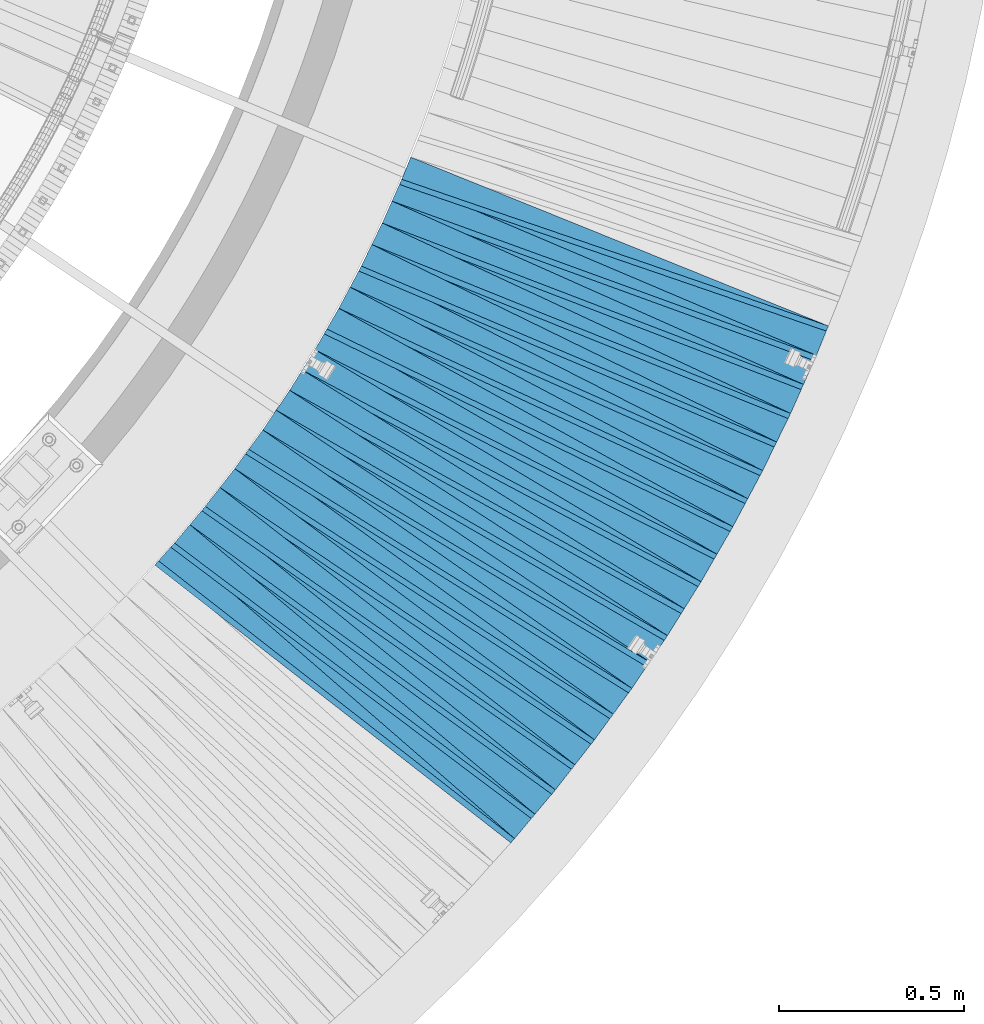
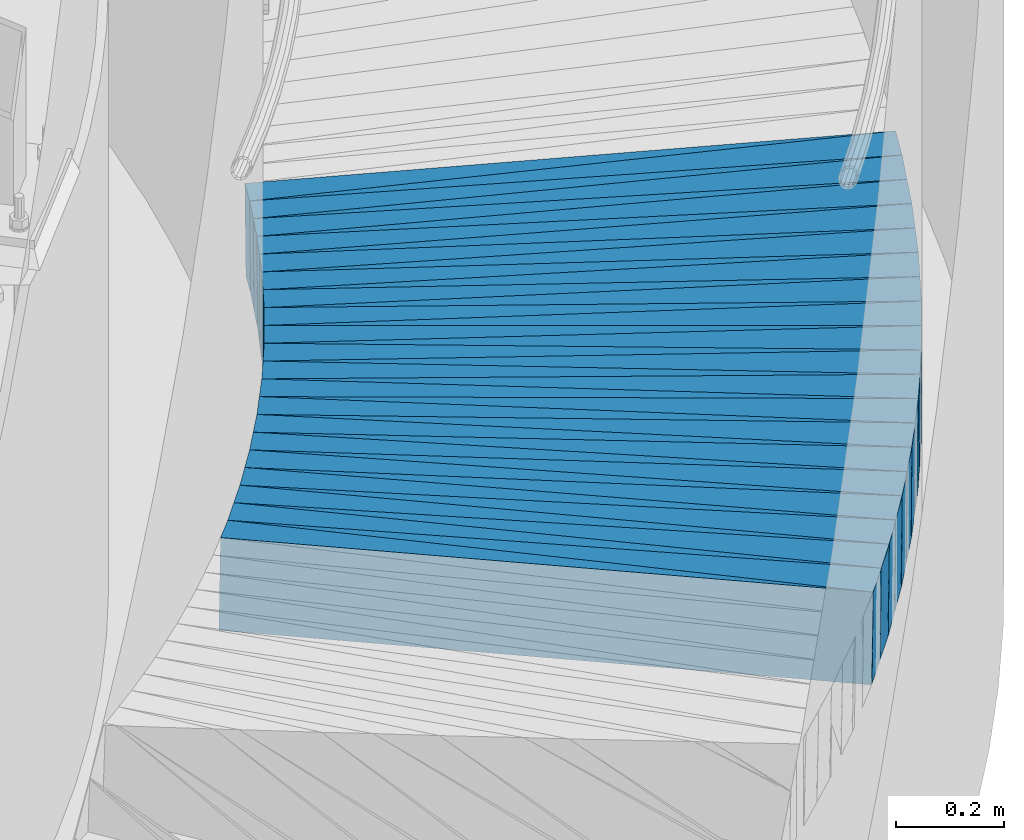
# One storey, part 833 of 975: 39 plates.
"""IFC2X3 building model written with IfcOpenShell, lengths in millimetres."""

from ifc_helpers import new_model, si_unit, frame, origin_with_axes, place, context, subcontext, project, spatial, faceted_brep, material, type_object, element, save


model = new_model("IFC2X3")

# Units and contexts
model_context = context("Model", 3, precision=1e-05, world=origin_with_axes())
body_context = subcontext(model_context, "Body", "Model", "MODEL_VIEW")
ifc_project = project(units=[si_unit("LENGTHUNIT", "METRE", prefix="MILLI"), si_unit("AREAUNIT", "SQUARE_METRE"), si_unit("VOLUMEUNIT", "CUBIC_METRE"), si_unit("MASSUNIT", "GRAM", prefix="KILO"), si_unit("TIMEUNIT", "SECOND"), si_unit("PLANEANGLEUNIT", "RADIAN"), si_unit("SOLIDANGLEUNIT", "STERADIAN"), si_unit("THERMODYNAMICTEMPERATUREUNIT", "DEGREE_CELSIUS"), si_unit("LUMINOUSINTENSITYUNIT", "LUMEN")], contexts=[model_context])

# Site, building, storey
site_placement = place(None, origin_with_axes())
site = spatial("IfcSite", under=ifc_project, at=site_placement, CompositionType="ELEMENT")
building_placement = place(site_placement, origin_with_axes())
building = spatial("IfcBuilding", under=site, at=building_placement, Name="Undefined", CompositionType="ELEMENT")
storey_placement = place(building_placement, origin_with_axes())
storey = spatial("IfcBuildingStorey", under=building, at=storey_placement, Name="Undefined", CompositionType="ELEMENT", Elevation=0.0)

# Plates
ifc_material = material(Name="STEEL/A36")
plate_type_1 = type_object("IfcPlateType", PredefinedType="NOTDEFINED")
plate_1_placement = place(storey_placement, frame((38504.8995301425, 232.330951646472, 537.762395960305), z_axis=(-0.600129828803423, -0.79788158190349, 0.0568257849884856), x_axis=(-0.799029166954348, 0.601278868965646, 0.00401398699977062)))
element("IfcPlate", 1, at=plate_1_placement, inside=storey, type_object=plate_type_1, material=ifc_material, Name="SLAB", context=body_context, shape_type="Brep", body=[
    faceted_brep([(-6.82121026329696e-12, -100.000000000011, -1.09139364212751e-10), (4.56192922573973, -100.000000000013, 85.90621948228), (4.56192922602713, 100.000000000003, 85.9062194825019), (5.91171556152403e-12, 100.000000000011, 1.09139364212751e-10), (1220.7314453137, -99.9999999999563, 3.34694050252438e-10), (1220.73144531398, 100.000000000059, 5.56610757485032e-10)], [[[0, 1, 2, 3]], [[1, 4, 5, 2]], [[4, 0, 3, 5]], [[5, 3, 2]], [[4, 1, 0]]]),
])
plate_2_placement = place(storey_placement, frame((38560.2068709719, 298.085949273894, 532.768471677697), z_axis=(-0.586114509571577, -0.808158354725775, 0.0578779349717851), x_axis=(-0.809369312502752, 0.587285770364803, 0.00409144300254147)))
element("IfcPlate", 2, at=plate_2_placement, inside=storey, type_object=plate_type_1, material=ifc_material, Name="SLAB", context=body_context, shape_type="Brep", body=[
    faceted_brep([(-6.82121026329696e-12, -100.000000000011, -1.09139364212751e-10), (6.07661056505822, -100.000000000004, 85.9591445921542), (6.07661056524375, 99.9999999999995, 85.9591445923361), (5.91171556152403e-12, 100.000000000011, 1.09139364212751e-10), (1222.06286620976, -100.000000000089, -2.08456185646355e-09), (1222.06286620995, 99.9999999999141, -1.90266291610897e-09)], [[[0, 1, 2, 3]], [[1, 4, 5, 2]], [[4, 0, 3, 5]], [[5, 3, 2]], [[4, 1, 0]]]),
])
plate_3_placement = place(storey_placement, frame((38613.2559058673, 365.908971802877, 527.861992789924), z_axis=(-0.571923051389691, -0.8183415572883, 0.0567549020267446), x_axis=(-0.81952539729027, 0.573028804202963, 0.00401406900142174)))
element("IfcPlate", 3, at=plate_3_placement, inside=storey, type_object=plate_type_1, material=ifc_material, Name="SLAB", context=body_context, shape_type="Brep", body=[
    faceted_brep([(-6.82121026329696e-12, -100.000000000011, -1.09139364212751e-10), (4.52120971723343, -99.9999999999807, 86.016387939766), (4.52120971684053, 99.999999999993, 86.0163879394859), (5.91171556152403e-12, 100.000000000011, 1.09139364212751e-10), (1220.70654296677, -100.000000000073, 1.41517375595868e-09), (1220.70654296638, 99.9999999999, 1.13868736661971e-09)], [[[0, 1, 2, 3]], [[1, 4, 5, 2]], [[4, 0, 3, 5]], [[5, 3, 2]], [[4, 1, 0]]]),
])
plate_4_placement = place(storey_placement, frame((38666.265364871, 433.560074700718, 522.868359591709), z_axis=(-0.557546238126437, -0.828127150024632, 0.0578585840056505), x_axis=(-0.829377363387287, 0.55867382926088, 0.00409165000191065)))
element("IfcPlate", 4, at=plate_4_placement, inside=storey, type_object=plate_type_1, material=ifc_material, Name="SLAB", context=body_context, shape_type="Brep", body=[
    faceted_brep([(-6.82121026329696e-12, -100.000000000011, -1.09139364212751e-10), (6.09937286372588, -100.0, 85.9862670898074), (6.0993728634312, 99.9999999999823, 85.9862670896182), (5.91171556152403e-12, 100.000000000011, 1.09139364212751e-10), (1222.00109863065, -100.000000000075, -2.01544025912881e-09), (1222.00109863035, 99.9999999999072, -2.20825313590467e-09)], [[[0, 1, 2, 3]], [[1, 4, 5, 2]], [[4, 0, 3, 5]], [[5, 3, 2]], [[4, 1, 0]]]),
])
plate_5_placement = place(storey_placement, frame((38716.8395153434, 502.989575731569, 517.868987072352), z_axis=(-0.542992831008908, -0.837734251577136, 0.0579664489806534), x_axis=(-0.839008829604706, 0.544102386743649, 0.00409592299807025)))
element("IfcPlate", 5, at=plate_5_placement, inside=storey, type_object=plate_type_1, material=ifc_material, Name="SLAB", context=body_context, shape_type="Brep", body=[
    faceted_brep([(-6.82121026329696e-12, -100.000000000011, -1.09139364212751e-10), (4.57530975338886, -99.9999999999984, 85.9335021972547), (4.57530975381815, 100.000000000013, 85.9335021975276), (5.91171556152403e-12, 100.000000000011, 1.09139364212751e-10), (1220.72607422123, -99.9999999999166, 4.15093381889164e-09), (1220.72607422166, 100.000000000095, 4.42742020823061e-09)], [[[0, 1, 2, 3]], [[1, 4, 5, 2]], [[4, 0, 3, 5]], [[5, 3, 2]], [[4, 1, 0]]]),
])
plate_6_placement = place(storey_placement, frame((38767.594689206, 572.631380242182, 512.961737475334), z_axis=(-0.528365499616847, -0.847120912608483, 0.0567103009691386), x_axis=(-0.848359035570189, 0.529406149731783, 0.0040094129979687)))
element("IfcPlate", 6, at=plate_6_placement, inside=storey, type_object=plate_type_1, material=ifc_material, Name="SLAB", context=body_context, shape_type="Brep", body=[
    faceted_brep([(-6.82121026329696e-12, -100.000000000011, -1.09139364212751e-10), (6.09994506832663, -99.9999999999966, 85.972793579087), (6.09994506831572, 99.9999999999925, 85.9727935790834), (5.91171556152403e-12, 100.000000000011, 1.09139364212751e-10), (1222.12402343539, -100.000000000138, 1.54614099301398e-09), (1222.12402343538, 99.9999999998511, 1.54614099301398e-09)], [[[0, 1, 2, 3]], [[1, 4, 5, 2]], [[4, 0, 3, 5]], [[5, 3, 2]], [[4, 1, 0]]]),
])
plate_7_placement = place(storey_placement, frame((38815.7736389934, 643.870614468133, 508.061943750297), z_axis=(-0.513423263162418, -0.856257211542976, 0.0567462820306519), x_axis=(-0.857514928625709, 0.514443422775455, 0.00401396899824797)))
element("IfcPlate", 7, at=plate_7_placement, inside=storey, type_object=plate_type_1, material=ifc_material, Name="SLAB", context=body_context, shape_type="Brep", body=[
    faceted_brep([(-6.82121026329696e-12, -100.000000000011, -1.09139364212751e-10), (4.58632040025986, -99.9999999999995, 86.0248565673865), (4.58632039996883, 99.9999999999911, 86.0248565672264), (5.91171556152403e-12, 100.000000000011, 1.09139364212751e-10), (1220.73681640689, -99.9999999999977, 1.5788828022778e-09), (1220.7368164066, 99.999999999993, 1.41881173476577e-09)], [[[0, 1, 2, 3]], [[1, 4, 5, 2]], [[4, 0, 3, 5]], [[5, 3, 2]], [[4, 1, 0]]]),
])
plate_8_placement = place(storey_placement, frame((38863.8911202831, 715.019259531534, 503.068553460164), z_axis=(-0.498441017450932, -0.86498847599125, 0.0578920419817283), x_axis=(-0.866315894896196, 0.49947975994015, 0.00409141299950974)))
element("IfcPlate", 8, at=plate_8_placement, inside=storey, type_object=plate_type_1, material=ifc_material, Name="SLAB", context=body_context, shape_type="Brep", body=[
    faceted_brep([(-6.82121026329696e-12, -100.000000000011, -1.09139364212751e-10), (6.07734489457653, -99.999999999993, 85.9381484986297), (6.07734489430004, 99.9999999999916, 85.9381484984733), (5.91171556152403e-12, 100.000000000011, 1.09139364212751e-10), (1222.07153320566, -99.9999999999113, -3.09228198602796e-10), (1222.07153320539, 100.000000000073, -4.69299266114831e-10)], [[[0, 1, 2, 3]], [[1, 4, 5, 2]], [[4, 0, 3, 5]], [[5, 3, 2]], [[4, 1, 0]]]),
])
plate_9_placement = place(storey_placement, frame((38909.5745806869, 787.861362029249, 498.068682214294), z_axis=(-0.483189245002955, -0.873598380325737, 0.0579139310159813), x_axis=(-0.874944745998459, 0.484205447999145, 0.00409579999999279)))
element("IfcPlate", 9, at=plate_9_placement, inside=storey, type_object=plate_type_1, material=ifc_material, Name="SLAB", context=body_context, shape_type="Brep", body=[
    faceted_brep([(-6.82121026329696e-12, -100.000000000011, -1.09139364212751e-10), (4.61938238157018, -99.9999999999952, 86.0083236695064), (4.61938238117727, 99.9999999999866, 86.0083236692808), (5.91171556152403e-12, 100.000000000011, 1.09139364212751e-10), (1220.76281738413, -99.9999999999754, -4.32919478043914e-10), (1220.76281738373, 100.000000000007, -6.584741640836e-10)], [[[0, 1, 2, 3]], [[1, 4, 5, 2]], [[4, 0, 3, 5]], [[5, 3, 2]], [[4, 1, 0]]]),
])
plate_10_placement = place(storey_placement, frame((38955.1615179338, 860.809501918946, 493.068509371963), z_axis=(-0.467918439399713, -0.881873986588402, 0.0578844180105143), x_axis=(-0.883236498904264, 0.468909953949175, 0.0040917099995565)))
element("IfcPlate", 10, at=plate_10_placement, inside=storey, type_object=plate_type_1, material=ifc_material, Name="SLAB", context=body_context, shape_type="Brep", body=[
    faceted_brep([(-6.82121026329696e-12, -100.000000000011, -1.09139364212751e-10), (5.97729253761645, -100.000000000003, 85.9565124511391), (5.97729253741272, 99.9999999999875, 85.9565124510264), (5.91171556152403e-12, 100.000000000011, 1.09139364212751e-10), (1221.9830322292, -99.9999999999052, 3.03771230392158e-09), (1221.98303222901, 100.000000000085, 2.92857293970883e-09)], [[[0, 1, 2, 3]], [[1, 4, 5, 2]], [[4, 0, 3, 5]], [[5, 3, 2]], [[4, 1, 0]]]),
])
plate_11_placement = place(storey_placement, frame((38998.2444734794, 935.150854828149, 488.068896753499), z_axis=(-0.45245510847104, -0.889902280813972, 0.0579508880048386), x_axis=(-0.891285074960768, 0.453424897980042, 0.00409597899981969)))
element("IfcPlate", 11, at=plate_11_placement, inside=storey, type_object=plate_type_1, material=ifc_material, Name="SLAB", context=body_context, shape_type="Brep", body=[
    faceted_brep([(-6.82121026329696e-12, -100.000000000011, -1.09139364212751e-10), (4.61092567443848, -100.0, 85.9540557861328), (4.61092567408923, 99.9999999999914, 85.9540557859618), (5.91171556152403e-12, 100.000000000011, 1.09139364212751e-10), (1220.70935058755, -99.9999999999611, 2.81943357549608e-09), (1220.70935058721, 100.00000000003, 2.65208655036986e-09)], [[[0, 1, 2, 3]], [[1, 4, 5, 2]], [[4, 0, 3, 5]], [[5, 3, 2]], [[4, 1, 0]]]),
])
plate_12_placement = place(storey_placement, frame((39041.3926919876, 1009.70552827916, 483.161852386607), z_axis=(-0.436951220943142, -0.89769442391659, 0.0567305189942656), x_axis=(-0.899035506395054, 0.437857376192405, 0.0040095330017619)))
element("IfcPlate", 12, at=plate_12_placement, inside=storey, type_object=plate_type_1, material=ifc_material, Name="SLAB", context=body_context, shape_type="Brep", body=[
    faceted_brep([(-6.82121026329696e-12, -100.000000000011, -1.09139364212751e-10), (6.05779886255914, -99.9999999999923, 85.9451141357931), (6.0577988626319, 100.000000000005, 85.9451141358368), (5.91171556152403e-12, 100.000000000011, 1.09139364212751e-10), (1222.08740234285, -100.000000000008, -3.18686943501234e-09), (1222.08740234292, 99.9999999999893, -3.14321368932724e-09)], [[[0, 1, 2, 3]], [[1, 4, 5, 2]], [[4, 0, 3, 5]], [[5, 3, 2]], [[4, 1, 0]]]),
])
plate_13_placement = place(storey_placement, frame((39081.8776924499, 1085.55372060486, 478.262036452608), z_axis=(-0.4211506887945, -0.905212740388843, 0.0567625930137048), x_axis=(-0.906570975158231, 0.42203430607366, 0.00401391300070056)))
element("IfcPlate", 13, at=plate_13_placement, inside=storey, type_object=plate_type_1, material=ifc_material, Name="SLAB", context=body_context, shape_type="Brep", body=[
    faceted_brep([(-6.82121026329696e-12, -100.000000000011, -1.09139364212751e-10), (4.61273193333182, -100.000000000011, 85.998268127325), (4.612731933943, 100.00000000001, 85.9982681275869), (5.91171556152403e-12, 100.000000000011, 1.09139364212751e-10), (1220.75378417907, -100.000000000089, -2.72848410531878e-10), (1220.75378417927, 99.9999999999472, 1.96450855582952e-10)], [[[0, 1, 2, 3]], [[1, 4, 5, 2]], [[4, 0, 3, 5]], [[5, 3, 2]], [[4, 1, 0]]]),
])
plate_14_placement = place(storey_placement, frame((39122.3135091974, 1161.41027650367, 473.268306998371), z_axis=(-0.405302654180486, -0.912350366344484, 0.0578495250225914), x_axis=(-0.913776903306864, 0.406195804136407, 0.00409141600137395)))
element("IfcPlate", 14, at=plate_14_placement, inside=storey, type_object=plate_type_1, material=ifc_material, Name="SLAB", context=body_context, shape_type="Brep", body=[
    faceted_brep([(-6.82121026329696e-12, -100.000000000011, -1.09139364212751e-10), (6.06616306289652, -100.000000000007, 86.0021057128215), (6.06616306317301, 100.000000000002, 86.0021057129488), (5.91171556152403e-12, 100.000000000011, 1.09139364212751e-10), (1222.07067870769, -100.000000000075, -2.29192664846778e-09), (1222.07067870796, 99.9999999999338, -2.16095941141248e-09)], [[[0, 1, 2, 3]], [[1, 4, 5, 2]], [[4, 0, 3, 5]], [[5, 3, 2]], [[4, 1, 0]]]),
])
plate_15_placement = place(storey_placement, frame((39160.1538102033, 1238.7615930514, 468.361959987438), z_axis=(-0.389261181087517, -0.919377652858531, 0.0567491349950812), x_axis=(-0.920765250109163, 0.390096452046248, 0.00401401200047586)))
element("IfcPlate", 15, at=plate_15_placement, inside=storey, type_object=plate_type_1, material=ifc_material, Name="SLAB", context=body_context, shape_type="Brep", body=[
    faceted_brep([(-6.82121026329696e-12, -100.000000000011, -1.09139364212751e-10), (4.57806301092205, -100.00000000001, 86.021110534557), (4.57806301146775, 100.000000000011, 86.0211105347753), (5.91171556152403e-12, 100.000000000011, 1.09139364212751e-10), (1220.72375487936, -100.000000000106, -4.74756234325469e-10), (1220.72375487992, 99.9999999999141, -2.58296495303512e-10)], [[[0, 1, 2, 3]], [[1, 4, 5, 2]], [[4, 0, 3, 5]], [[5, 3, 2]], [[4, 1, 0]]]),
])
plate_16_placement = place(storey_placement, frame((39197.8923728056, 1315.9140566369, 463.368569825984), z_axis=(-0.373180319535365, -0.925950664277369, 0.0578948740026521), x_axis=(-0.927409905704524, 0.374024234880835, 0.00409127399869651)))
element("IfcPlate", 16, at=plate_16_placement, inside=storey, type_object=plate_type_1, material=ifc_material, Name="SLAB", context=body_context, shape_type="Brep", body=[
    faceted_brep([(-6.82121026329696e-12, -100.000000000011, -1.09139364212751e-10), (6.07173633566708, -100.000000000006, 85.934356689424), (6.07173633553612, 99.9999999999957, 85.9343566893822), (5.91171556152403e-12, 100.000000000011, 1.09139364212751e-10), (1222.1132812534, -99.9999999999268, 1.54795998241752e-09), (1222.11328125327, 100.000000000075, 1.50430423673242e-09)], [[[0, 1, 2, 3]], [[1, 4, 5, 2]], [[4, 0, 3, 5]], [[5, 3, 2]], [[4, 1, 0]]]),
])
plate_17_placement = place(storey_placement, frame((39232.8835267741, 1394.46923122308, 458.368640701248), z_axis=(-0.356855969666161, -0.932362925699002, 0.0579067500005057), x_axis=(-0.933837273636278, 0.35767466786069, 0.0040961369984046)))
element("IfcPlate", 17, at=plate_17_placement, inside=storey, type_object=plate_type_1, material=ifc_material, Name="SLAB", context=body_context, shape_type="Brep", body=[
    faceted_brep([(-6.82121026329696e-12, -100.000000000011, -1.09139364212751e-10), (4.49817276006797, -99.9999999999948, 86.0275344848833), (4.49817275979876, 99.9999999999939, 86.0275344847742), (5.91171556152403e-12, 100.000000000011, 1.09139364212751e-10), (1220.66235351813, -99.9999999999084, 2.83398549072444e-09), (1220.66235351785, 100.00000000008, 2.72484612651169e-09)], [[[0, 1, 2, 3]], [[1, 4, 5, 2]], [[4, 0, 3, 5]], [[5, 3, 2]], [[4, 1, 0]]]),
])
plate_18_placement = place(storey_placement, frame((39267.9743079535, 1472.925187115, 453.368782230598), z_axis=(-0.340703604583556, -0.938384249839842, 0.0579314549816342), x_axis=(-0.939873930514889, 0.341497075187082, 0.00409174500224159)))
element("IfcPlate", 18, at=plate_18_placement, inside=storey, type_object=plate_type_1, material=ifc_material, Name="SLAB", context=body_context, shape_type="Brep", body=[
    faceted_brep([(-6.82121026329696e-12, -100.000000000011, -1.09139364212751e-10), (6.10852575315221, -99.9999999999993, 85.8774490356918), (6.10852575280296, 99.999999999993, 85.8774490355645), (5.91171556152403e-12, 100.000000000011, 1.09139364212751e-10), (1221.97241211307, -99.9999999999295, -2.77577782981098e-09), (1221.97241211273, 100.000000000063, -2.90310708805919e-09)], [[[0, 1, 2, 3]], [[1, 4, 5, 2]], [[4, 0, 3, 5]], [[5, 3, 2]], [[4, 1, 0]]]),
])
plate_19_placement = place(storey_placement, frame((39300.4133524845, 1552.69353007327, 448.461980465852), z_axis=(-0.324223807843024, -0.944276468062056, 0.0567527469997595), x_axis=(-0.945719109273629, 0.324960390094021, 0.00401387900116132)))
element("IfcPlate", 19, at=plate_19_placement, inside=storey, type_object=plate_type_1, material=ifc_material, Name="SLAB", context=body_context, shape_type="Brep", body=[
    faceted_brep([(-6.82121026329696e-12, -100.000000000011, -1.09139364212751e-10), (4.66705226884369, -100.000000000002, 86.0093536376608), (4.66705226952763, 100.000000000017, 86.0093536378772), (5.91171556152403e-12, 100.000000000011, 1.09139364212751e-10), (1220.76416015557, -100.000000000003, -3.40878614224494e-09), (1220.76416015626, 100.000000000016, -3.19232640322298e-09)], [[[0, 1, 2, 3]], [[1, 4, 5, 2]], [[4, 0, 3, 5]], [[5, 3, 2]], [[4, 1, 0]]]),
])
plate_type_2 = type_object("IfcPlateType", PredefinedType="NOTDEFINED")
plate_20_placement = place(storey_placement, frame((38448.3827844014, 165.015986113746, 542.797196594463), z_axis=(-0.654054439086626, -0.752514246617297, 0.0770395959820718), x_axis=(-0.754757359802759, 0.656004060828566, 0.0)))
element("IfcPlate", 20, at=plate_20_placement, inside=storey, type_object=plate_type_2, material=ifc_material, Name="SLAB", context=body_context, shape_type="Brep", body=[
    faceted_brep([(-6.82121026329696e-12, -100.000000000011, -1.09139364212751e-10), (1220.32702636992, -99.9999999998249, 64.9016876244386), (1220.32702637023, 100.000000000206, 64.9016876247115), (5.91171556152403e-12, 100.000000000011, 1.09139364212751e-10), (1219.19982910421, -99.9999999998277, 2.30647856369615e-09), (1219.19982910452, 100.000000000203, 2.58296495303512e-09)], [[[0, 1, 2, 3]], [[1, 4, 5, 2]], [[4, 0, 3, 5]], [[5, 3, 2]], [[4, 1, 0]]]),
])
plate_21_placement = place(storey_placement, frame((38503.7849060935, 230.848926797457, 537.885241209586), z_axis=(-0.640977521971603, -0.76383972685049, 0.0754764069899492), x_axis=(-0.76602474512809, 0.642811084107488, 0.0)))
element("IfcPlate", 21, at=plate_21_placement, inside=storey, type_object=plate_type_2, material=ifc_material, Name="SLAB", context=body_context, shape_type="Brep", body=[
    faceted_brep([(-6.82121026329696e-12, -100.000000000011, -1.09139364212751e-10), (1219.00390624964, -100.000000000028, 64.920951842978), (1219.00390624963, 99.9999999999791, 64.9209518429707), (5.91171556152403e-12, 100.000000000011, 1.09139364212751e-10), (1219.02062988339, -99.9999999998413, 1.29512045532465e-09), (1219.02062988328, 100.000000000125, 9.24046617001295e-10)], [[[0, 1, 2, 3]], [[1, 4, 5, 2]], [[4, 0, 3, 5]], [[5, 3, 2]], [[4, 1, 0]]]),
])
plate_22_placement = place(storey_placement, frame((38559.0895356837, 296.54519524909, 532.897037684428), z_axis=(-0.627465705727452, -0.774825694986044, 0.0770190270345272), x_axis=(-0.777134076040823, 0.62933506803306, 0.0)))
element("IfcPlate", 22, at=plate_22_placement, inside=storey, type_object=plate_type_2, material=ifc_material, Name="SLAB", context=body_context, shape_type="Brep", body=[
    faceted_brep([(-6.82121026329696e-12, -100.000000000011, -1.09139364212751e-10), (1220.33703612935, -100.000000000217, 64.9190216036259), (1220.33703612985, 99.9999999998076, 64.919021604037), (5.91171556152403e-12, 100.000000000011, 1.09139364212751e-10), (1219.22338867366, -99.999999999824, 4.28190105594695e-09), (1219.22338867346, 100.000000000151, 4.0381564758718e-09)], [[[0, 1, 2, 3]], [[1, 4, 5, 2]], [[4, 0, 3, 5]], [[5, 3, 2]], [[4, 1, 0]]]),
])
plate_23_placement = place(storey_placement, frame((38612.1907938346, 364.38482421866, 527.985086179519), z_axis=(-0.61394448610879, -0.785734415572353, 0.0754559219795689), x_axis=(-0.787980840038391, 0.615699761029995, 0.0)))
element("IfcPlate", 23, at=plate_23_placement, inside=storey, type_object=plate_type_2, material=ifc_material, Name="SLAB", context=body_context, shape_type="Brep", body=[
    faceted_brep([(-6.82121026329696e-12, -100.000000000011, -1.09139364212751e-10), (1218.97802734489, -99.9999999999345, 64.9385757455348), (1218.97802734473, 100.000000000057, 64.9385757454038), (5.91171556152403e-12, 100.000000000011, 1.09139364212751e-10), (1218.9382324229, -99.9999999999391, 8.51287040859461e-10), (1218.93823242274, 100.000000000053, 7.23957782611251e-10)], [[[0, 1, 2, 3]], [[1, 4, 5, 2]], [[4, 0, 3, 5]], [[5, 3, 2]], [[4, 1, 0]]]),
])
plate_24_placement = place(storey_placement, frame((38665.1985324902, 431.975366921641, 522.99743616172), z_axis=(-0.600006449708255, -0.796274063277483, 0.0770705940035588), x_axis=(-0.798649535823537, 0.601796409867033, 0.0)))
element("IfcPlate", 24, at=plate_24_placement, inside=storey, type_object=plate_type_2, material=ifc_material, Name="SLAB", context=body_context, shape_type="Brep", body=[
    faceted_brep([(-6.82121026329696e-12, -100.000000000011, -1.09139364212751e-10), (1220.27770995717, -100.000000000215, 64.8755874605886), (1220.27770995751, 99.9999999998049, 64.8755874608432), (5.91171556152403e-12, 100.000000000011, 1.09139364212751e-10), (1219.18310546512, -100.000000000208, -5.27506927028298e-10), (1219.18310546545, 99.9999999998117, -2.7648638933897e-10)], [[[0, 1, 2, 3]], [[1, 4, 5, 2]], [[4, 0, 3, 5]], [[5, 3, 2]], [[4, 1, 0]]]),
])
plate_25_placement = place(storey_placement, frame((38715.8093506098, 501.400092329706, 517.997018151486), z_axis=(-0.586084258422626, -0.806581490557313, 0.0770164990086096), x_axis=(-0.808984320860555, 0.587830220898677, 0.0)))
element("IfcPlate", 25, at=plate_25_placement, inside=storey, type_object=plate_type_2, material=ifc_material, Name="SLAB", context=body_context, shape_type="Brep", body=[
    faceted_brep([(-6.82121026329696e-12, -100.000000000011, -1.09139364212751e-10), (1218.99853515379, -100.000000000141, 64.9211578351023), (1218.99853515397, 99.999999999864, 64.9211578352406), (5.91171556152403e-12, 100.000000000011, 1.09139364212751e-10), (1219.05944823973, -100.000000000137, 9.67702362686396e-10), (1219.05944823991, 99.9999999998677, 1.11322151497006e-09)], [[[0, 1, 2, 3]], [[1, 4, 5, 2]], [[4, 0, 3, 5]], [[5, 3, 2]], [[4, 1, 0]]]),
])
plate_26_placement = place(storey_placement, frame((38766.6047348856, 571.044067157343, 513.0856000168), z_axis=(-0.571939801031353, -0.816811496235576, 0.0755237950159778), x_axis=(-0.81915099161122, 0.573577939727771, 0.0)))
element("IfcPlate", 26, at=plate_26_placement, inside=storey, type_object=plate_type_2, material=ifc_material, Name="SLAB", context=body_context, shape_type="Brep", body=[
    faceted_brep([(-6.82121026329696e-12, -100.000000000011, -1.09139364212751e-10), (1220.40063476881, -99.9999999998399, 64.8802108786695), (1220.40063476851, 100.000000000155, 64.8802108784657), (5.91171556152403e-12, 100.000000000011, 1.09139364212751e-10), (1219.18920898512, -99.9999999999104, -1.30967237055302e-09), (1219.18920898551, 100.000000000124, -7.49423634260893e-10)], [[[0, 1, 2, 3]], [[1, 4, 5, 2]], [[4, 0, 3, 5]], [[5, 3, 2]], [[4, 1, 0]]]),
])
plate_27_placement = place(storey_placement, frame((38814.8175550012, 642.275977924812, 508.18501029377), z_axis=(-0.557622585540105, -0.826658919580766, 0.0754458930169699), x_axis=(-0.8290217168048, 0.559216409868328, 0.0)))
element("IfcPlate", 27, at=plate_27_placement, inside=storey, type_object=plate_type_2, material=ifc_material, Name="SLAB", context=body_context, shape_type="Brep", body=[
    faceted_brep([(-6.82121026329696e-12, -100.000000000011, -1.09139364212751e-10), (1219.0078124987, -100.000000000067, 64.9472045889634), (1219.00781249818, 99.9999999999063, 64.9472045886287), (5.91171556152403e-12, 100.000000000011, 1.09139364212751e-10), (1219.02722168136, -99.999999999824, 9.45874489843845e-10), (1219.02722168136, 100.000000000183, 9.56788426265121e-10)], [[[0, 1, 2, 3]], [[1, 4, 5, 2]], [[4, 0, 3, 5]], [[5, 3, 2]], [[4, 1, 0]]]),
])
plate_28_placement = place(storey_placement, frame((38862.9382324902, 713.36547945398, 503.197564049041), z_axis=(-0.543007304275466, -0.836182181685406, 0.0770871359912), x_axis=(-0.838677785257772, 0.544627921167395, 0.0)))
element("IfcPlate", 28, at=plate_28_placement, inside=storey, type_object=plate_type_2, material=ifc_material, Name="SLAB", context=body_context, shape_type="Brep", body=[
    faceted_brep([(-6.82121026329696e-12, -100.000000000011, -1.09139364212751e-10), (1220.34899902307, -100.000000000013, 64.8616638181593), (1220.34899902293, 99.9999999999764, 64.8616638180538), (5.91171556152403e-12, 100.000000000011, 1.09139364212751e-10), (1219.18103027422, -99.9999999999109, 3.14321368932724e-09), (1219.1810302739, 100.000000000047, 2.62662069872022e-09)], [[[0, 1, 2, 3]], [[1, 4, 5, 2]], [[4, 0, 3, 5]], [[5, 3, 2]], [[4, 1, 0]]]),
])
plate_29_placement = place(storey_placement, frame((38908.6556748241, 786.199841526181, 498.196965674616), z_axis=(-0.528351505949876, -0.845525985109578, 0.0770097050051262), x_axis=(-0.848044385855469, 0.529925201909685, 0.0)))
element("IfcPlate", 29, at=plate_29_placement, inside=storey, type_object=plate_type_2, material=ifc_material, Name="SLAB", context=body_context, shape_type="Brep", body=[
    faceted_brep([(-6.82121026329696e-12, -100.000000000011, -1.09139364212751e-10), (1219.03503418159, -99.9999999999104, 64.9268798839985), (1219.035034181, 100.000000000062, 64.9268798836201), (5.91171556152403e-12, 100.000000000011, 1.09139364212751e-10), (1219.03991699267, -99.9999999999413, -3.20142135024071e-10), (1219.03991699259, 100.000000000047, -4.51109372079372e-10)], [[[0, 1, 2, 3]], [[1, 4, 5, 2]], [[4, 0, 3, 5]], [[5, 3, 2]], [[4, 1, 0]]]),
])
plate_30_placement = place(storey_placement, frame((38954.2697213525, 859.128596546511, 493.197055025602), z_axis=(-0.513508521303913, -0.854620806091784, 0.0770212720181695), x_axis=(-0.857167063933036, 0.515038468959764, 0.0)))
element("IfcPlate", 30, at=plate_30_placement, inside=storey, type_object=plate_type_2, material=ifc_material, Name="SLAB", context=body_context, shape_type="Brep", body=[
    faceted_brep([(-6.82121026329696e-12, -100.000000000011, -1.09139364212751e-10), (1220.25744629179, -99.9999999998759, 64.9171295181841), (1220.25744629217, 100.00000000014, 64.9171295183987), (5.91171556152403e-12, 100.000000000011, 1.09139364212751e-10), (1219.13220215114, -99.9999999998777, 3.5106495488435e-09), (1219.13220215152, 100.000000000138, 3.72529029846191e-09)], [[[0, 1, 2, 3]], [[1, 4, 5, 2]], [[4, 0, 3, 5]], [[5, 3, 2]], [[4, 1, 0]]]),
])
plate_31_placement = place(storey_placement, frame((38997.3856922253, 933.461614807377, 488.196966142427), z_axis=(-0.498571184313754, -0.863421258868528, 0.0770097650033244), x_axis=(-0.865992964746304, 0.500056181853506, 0.0)))
element("IfcPlate", 31, at=plate_31_placement, inside=storey, type_object=plate_type_2, material=ifc_material, Name="SLAB", context=body_context, shape_type="Brep", body=[
    faceted_brep([(-6.82121026329696e-12, -100.000000000011, -1.09139364212751e-10), (1218.98144531372, -99.9999999999486, 64.9268341070929), (1218.98144531338, 100.000000000035, 64.9268341068891), (5.91171556152403e-12, 100.000000000011, 1.09139364212751e-10), (1219.06298828263, -99.9999999999427, -2.83398549072444e-09), (1219.06298828228, 100.00000000004, -3.03771230392158e-09)], [[[0, 1, 2, 3]], [[1, 4, 5, 2]], [[4, 0, 3, 5]], [[5, 3, 2]], [[4, 1, 0]]]),
])
plate_32_placement = place(storey_placement, frame((39040.5744863591, 1008.02440466287, 483.285673410367), z_axis=(-0.483449835623636, -0.872107188983065, 0.0755334850217818), x_axis=(-0.874605704963633, 0.484834879979841, 0.0)))
element("IfcPlate", 32, at=plate_32_placement, inside=storey, type_object=plate_type_2, material=ifc_material, Name="SLAB", context=body_context, shape_type="Brep", body=[
    faceted_brep([(-6.82121026329696e-12, -100.000000000011, -1.09139364212751e-10), (1220.3643798837, -99.9999999999643, 64.8718948368769), (1220.36437988413, 100.000000000052, 64.8718948371024), (5.91171556152403e-12, 100.000000000011, 1.09139364212751e-10), (1219.17797851483, -100.000000000108, -2.062733983621e-09), (1219.17797851513, 99.9999999999245, -1.54250301420689e-09)], [[[0, 1, 2, 3]], [[1, 4, 5, 2]], [[4, 0, 3, 5]], [[5, 3, 2]], [[4, 1, 0]]]),
])
plate_33_placement = place(storey_placement, frame((39081.0948435559, 1083.8709162123, 478.384883814031), z_axis=(-0.468211361768269, -0.880391140497309, 0.0754291750249829), x_axis=(-0.882906397937149, 0.469549030966574, 0.0)))
element("IfcPlate", 33, at=plate_33_placement, inside=storey, type_object=plate_type_2, material=ifc_material, Name="SLAB", context=body_context, shape_type="Brep", body=[
    faceted_brep([(-6.82121026329696e-12, -100.000000000011, -1.09139364212751e-10), (1219.0241699202, -100.000000000069, 64.9616012563783), (1219.02416992011, 99.999999999925, 64.9616012563311), (5.91171556152403e-12, 100.000000000011, 1.09139364212751e-10), (1219.04199218588, -100.000000000068, 2.64117261394858e-09), (1219.04199218578, 99.9999999999259, 2.5902409106493e-09)], [[[0, 1, 2, 3]], [[1, 4, 5, 2]], [[4, 0, 3, 5]], [[5, 3, 2]], [[4, 1, 0]]]),
])
plate_34_placement = place(storey_placement, frame((39121.5374086951, 1159.66306196254, 473.397480458876), z_axis=(-0.45264159233906, -0.888355125589269, 0.0770763240173925), x_axis=(-0.891005693418618, 0.453992130213298, 0.0)))
element("IfcPlate", 34, at=plate_34_placement, inside=storey, type_object=plate_type_2, material=ifc_material, Name="SLAB", context=body_context, shape_type="Brep", body=[
    faceted_brep([(-6.82121026329696e-12, -100.000000000011, -1.09139364212751e-10), (1220.34777831991, -100.000000000013, 64.8707656859006), (1220.34777831991, 99.9999999999918, 64.8707656859151), (5.91171556152403e-12, 100.000000000011, 1.09139364212751e-10), (1219.18408203084, -100.000000000012, 6.83940015733242e-10), (1219.18408203083, 99.9999999999927, 6.94853952154517e-10)], [[[0, 1, 2, 3]], [[1, 4, 5, 2]], [[4, 0, 3, 5]], [[5, 3, 2]], [[4, 1, 0]]]),
])
plate_35_placement = place(storey_placement, frame((39159.4269689807, 1237.04472099207, 468.485417235235), z_axis=(-0.437114279378817, -0.89623150380087, 0.0754996579990219), x_axis=(-0.898796824827528, 0.438365449915881, 0.0)))
element("IfcPlate", 35, at=plate_35_placement, inside=storey, type_object=plate_type_2, material=ifc_material, Name="SLAB", context=body_context, shape_type="Brep", body=[
    faceted_brep([(-6.82121026329696e-12, -100.000000000011, -1.09139364212751e-10), (1218.99731445084, -100.000000000082, 64.9009551991003), (1218.99731445096, 99.9999999999184, 64.900955199173), (5.91171556152403e-12, 100.000000000011, 1.09139364212751e-10), (1219.07421874792, -100.000000000073, -4.01632860302925e-09), (1219.07421874804, 99.999999999927, -3.94356902688742e-09)], [[[0, 1, 2, 3]], [[1, 4, 5, 2]], [[4, 0, 3, 5]], [[5, 3, 2]], [[4, 1, 0]]]),
])
plate_36_placement = place(storey_placement, frame((39197.1786385296, 1314.1429084149, 463.497654593747), z_axis=(-0.421313324564646, -0.903632032682738, 0.0770988459962154), x_axis=(-0.906329764864502, 0.422571126936824, 0.0)))
element("IfcPlate", 36, at=plate_36_placement, inside=storey, type_object=plate_type_2, material=ifc_material, Name="SLAB", context=body_context, shape_type="Brep", body=[
    faceted_brep([(-6.82121026329696e-12, -100.000000000011, -1.09139364212751e-10), (1220.39135742616, -99.9999999998527, 64.8518142719367), (1220.39135742569, 100.000000000135, 64.8518142717185), (5.91171556152403e-12, 100.000000000011, 1.09139364212751e-10), (1219.20300293395, -99.999999999854, -7.49423634260893e-10), (1219.20300293349, 100.000000000134, -9.67702362686396e-10)], [[[0, 1, 2, 3]], [[1, 4, 5, 2]], [[4, 0, 3, 5]], [[5, 3, 2]], [[4, 1, 0]]]),
])
plate_37_placement = place(storey_placement, frame((39232.2082621349, 1392.70475141934, 458.496184712), z_axis=(-0.405557796478511, -0.910828168224733, 0.0769085280308503), x_axis=(-0.913533916014765, 0.406762565006574, 0.0)))
element("IfcPlate", 37, at=plate_37_placement, inside=storey, type_object=plate_type_2, material=ifc_material, Name="SLAB", context=body_context, shape_type="Brep", body=[
    faceted_brep([(-6.82121026329696e-12, -100.000000000011, -1.09139364212751e-10), (1218.92980956787, -100.00000000009, 65.012298582853), (1218.92980956843, 99.9999999999352, 65.0122985831185), (5.91171556152403e-12, 100.000000000011, 1.09139364212751e-10), (1218.89294433367, -100.000000000084, 2.61206878349185e-09), (1218.89294433423, 99.9999999999416, 2.87764123640954e-09)], [[[0, 1, 2, 3]], [[1, 4, 5, 2]], [[4, 0, 3, 5]], [[5, 3, 2]], [[4, 1, 0]]]),
])
plate_38_placement = place(storey_placement, frame((39267.3247251016, 1471.1358523878, 453.497477478472), z_axis=(-0.38960646144244, -0.917750567955232, 0.0770759380101799), x_axis=(-0.92048881484157, 0.390768910932742, 0.0)))
element("IfcPlate", 38, at=plate_38_placement, inside=storey, type_object=plate_type_2, material=ifc_material, Name="SLAB", context=body_context, shape_type="Brep", body=[
    faceted_brep([(-6.82121026329696e-12, -100.000000000011, -1.09139364212751e-10), (1220.24926758224, -99.9999999998745, 64.8710861222353), (1220.24926758252, 100.000000000136, 64.8710861223699), (5.91171556152403e-12, 100.000000000011, 1.09139364212751e-10), (1219.13488769924, -99.9999999998799, -1.95359461940825e-09), (1219.13488769951, 100.000000000131, -1.81535142473876e-09)], [[[0, 1, 2, 3]], [[1, 4, 5, 2]], [[4, 0, 3, 5]], [[5, 3, 2]], [[4, 1, 0]]]),
])
plate_39_placement = place(storey_placement, frame((39299.8073560067, 1550.92839621706, 448.585586007728), z_axis=(-0.373557271374389, -0.924527663636405, 0.0755219449850902), x_axis=(-0.927175547246217, 0.374627154099484, 0.0)))
element("IfcPlate", 39, at=plate_39_placement, inside=storey, type_object=plate_type_2, material=ifc_material, Name="SLAB", context=body_context, shape_type="Brep", body=[
    faceted_brep([(-6.82121026329696e-12, -100.000000000011, -1.09139364212751e-10), (1219.03881835636, -100.000000000093, 64.8818054187141), (1219.03881835703, 99.9999999999297, 64.8818054189942), (5.91171556152403e-12, 100.000000000011, 1.09139364212751e-10), (1219.07873535266, -99.9999999997826, 3.84170562028885e-09), (1219.07873535286, 100.000000000259, 4.34374669566751e-09)], [[[0, 1, 2, 3]], [[1, 4, 5, 2]], [[4, 0, 3, 5]], [[5, 3, 2]], [[4, 1, 0]]]),
])

save(model, "model.ifc")
